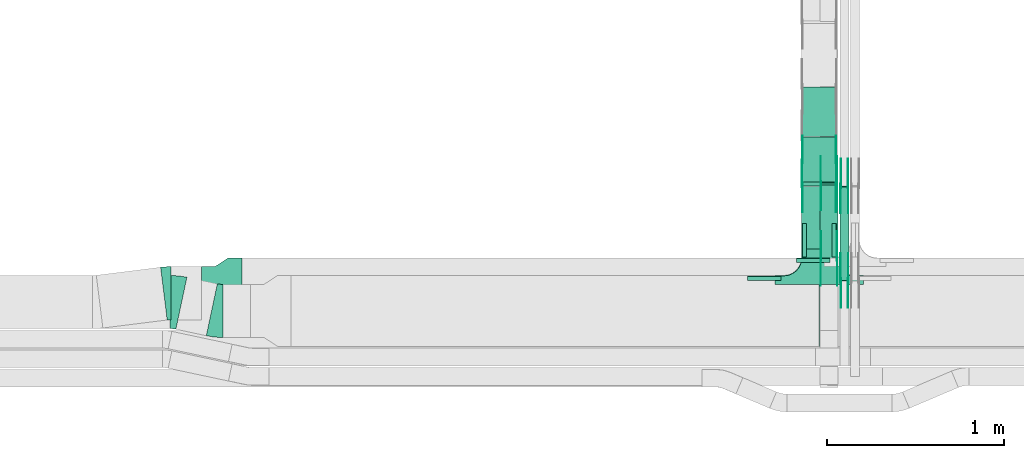
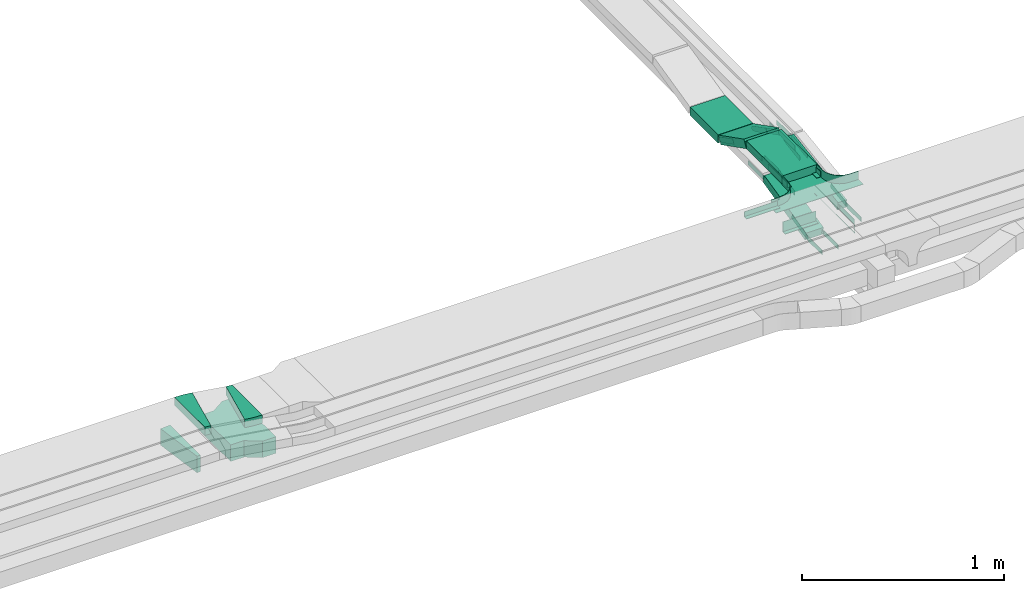
# One storey, part 17 of 27: 31 flow fittings, 5 flow segments.
"""IFC2X3 building model written with IfcOpenShell, lengths in millimetres."""

from ifc_helpers import new_model, entity, si_unit, converted_unit, derived_unit, direction, frame, frame_2d, origin, origin_2d_with_axis, place, context, subcontext, project, spatial, polyline, circle_curve, parameter, trimmed, segment, composite_curve, rectangle, outline, extrude, faceted_brep, source, transform, mapped, material, type_object, type_shapes, element, save


model = new_model("IFC2X3")

# Units and contexts
model_context = context("Model", 3, precision=0.01, world=origin(), true_north=direction((6.12303176911189e-17, 1.0)))
body_context = subcontext(model_context, "Body", "Model", "MODEL_VIEW")
ifc_project = project(units=[si_unit("LENGTHUNIT", "METRE", prefix="MILLI"), si_unit("AREAUNIT", "SQUARE_METRE"), si_unit("VOLUMEUNIT", "CUBIC_METRE"), converted_unit("PLANEANGLEUNIT", "DEGREE", entity("IfcRatioMeasure", 0.0174532925199433), si_unit("PLANEANGLEUNIT", "RADIAN"), dimensions=[0, 0, 0, 0, 0, 0, 0]), si_unit("MASSUNIT", "GRAM", prefix="KILO"), derived_unit("MASSDENSITYUNIT", [(si_unit("MASSUNIT", "GRAM", prefix="KILO"), 1), (si_unit("LENGTHUNIT", "METRE"), -3)]), derived_unit("MOMENTOFINERTIAUNIT", [(si_unit("LENGTHUNIT", "METRE"), 4)]), si_unit("TIMEUNIT", "SECOND"), si_unit("FREQUENCYUNIT", "HERTZ"), si_unit("THERMODYNAMICTEMPERATUREUNIT", "DEGREE_CELSIUS"), derived_unit("THERMALTRANSMITTANCEUNIT", [(si_unit("MASSUNIT", "GRAM", prefix="KILO"), 1), (si_unit("THERMODYNAMICTEMPERATUREUNIT", "KELVIN"), -1), (si_unit("TIMEUNIT", "SECOND"), -3)]), derived_unit("VOLUMETRICFLOWRATEUNIT", [(si_unit("LENGTHUNIT", "METRE"), 3), (si_unit("TIMEUNIT", "SECOND"), -1)]), derived_unit("MASSFLOWRATEUNIT", [(si_unit("MASSUNIT", "GRAM", prefix="KILO"), 1), (si_unit("TIMEUNIT", "SECOND"), -1)]), derived_unit("ROTATIONALFREQUENCYUNIT", [(si_unit("TIMEUNIT", "SECOND"), -1)]), si_unit("ELECTRICCURRENTUNIT", "AMPERE"), si_unit("ELECTRICVOLTAGEUNIT", "VOLT"), si_unit("POWERUNIT", "WATT"), si_unit("FORCEUNIT", "NEWTON", prefix="KILO"), si_unit("ILLUMINANCEUNIT", "LUX"), si_unit("LUMINOUSFLUXUNIT", "LUMEN"), si_unit("LUMINOUSINTENSITYUNIT", "CANDELA"), derived_unit("USERDEFINED", [(si_unit("MASSUNIT", "GRAM", prefix="KILO"), -1), (si_unit("LENGTHUNIT", "METRE"), -2), (si_unit("TIMEUNIT", "SECOND"), 3), (si_unit("LUMINOUSFLUXUNIT", "LUMEN"), 1)]), derived_unit("LINEARVELOCITYUNIT", [(si_unit("LENGTHUNIT", "METRE"), 1), (si_unit("TIMEUNIT", "SECOND"), -1)]), si_unit("PRESSUREUNIT", "PASCAL"), derived_unit("USERDEFINED", [(si_unit("LENGTHUNIT", "METRE"), -2), (si_unit("MASSUNIT", "GRAM", prefix="KILO"), 1), (si_unit("TIMEUNIT", "SECOND"), -2)]), derived_unit("LINEARFORCEUNIT", [(si_unit("MASSUNIT", "GRAM", prefix="KILO"), 1), (si_unit("LENGTHUNIT", "METRE"), 1), (si_unit("TIMEUNIT", "SECOND"), -2), (si_unit("LENGTHUNIT", "METRE"), -1)]), derived_unit("PLANARFORCEUNIT", [(si_unit("MASSUNIT", "GRAM", prefix="KILO"), 1), (si_unit("LENGTHUNIT", "METRE"), 1), (si_unit("TIMEUNIT", "SECOND"), -2), (si_unit("LENGTHUNIT", "METRE"), -2)])], contexts=[model_context])

# Site, building, storey
site_placement = place(None, origin())
site = spatial("IfcSite", under=ifc_project, at=site_placement, CompositionType="ELEMENT")
building_placement = place(site_placement, origin())
building = spatial("IfcBuilding", under=site, at=building_placement, CompositionType="ELEMENT")
storey_placement = place(building_placement, origin())
storey = spatial("IfcBuildingStorey", under=building, at=storey_placement, CompositionType="ELEMENT", Elevation=0.0)

# Flow segments
cable_carrier_segment_type = type_object("IfcCableCarrierSegmentType", PredefinedType="CABLETRAYSEGMENT")
flow_segment_1_placement = place(storey_placement, frame((46847.77, 9014.64, 2501.67)))
element("IfcFlowSegment", 1, at=flow_segment_1_placement, inside=storey, type_object=cable_carrier_segment_type, context=body_context, shape_type="SweptSolid", body=[
    extrude(rectangle(XDim=50.0000000000002, YDim=426.657179477889, at=frame_2d((0.0, 0.0), x_axis=(0.0, 1.0))), frame((0.0, 213.37, 73.33), z_axis=(1.0, 0.0, 0.0), x_axis=(0.0, -0.973268623518936, -0.229669733472992)), (0.0, 0.0, 1.0), 99.9999999999945),
])
flow_segment_2_placement = place(storey_placement, frame((46959.82, 8891.7, 2720.75)))
element("IfcFlowSegment", 2, at=flow_segment_2_placement, inside=storey, type_object=cable_carrier_segment_type, context=body_context, shape_type="SweptSolid", body=[
    extrude(rectangle(XDim=49.9999999999999, YDim=533.151523501312, at=frame_2d((0.0, 0.0), x_axis=(0.0, 1.0))), frame((0.0, 267.34, 64.25), z_axis=(1.0, 0.0, 0.0), x_axis=(0.0, 0.988943608506524, 0.148292073942251)), (0.0, 0.0, 1.0), 50.000000000006),
])
flow_segment_3_placement = place(storey_placement, frame((46742.18, 9070.0, 2850.0)))
element("IfcFlowSegment", 3, at=flow_segment_3_placement, inside=storey, type_object=cable_carrier_segment_type, context=body_context, shape_type="SweptSolid", body=[
    extrude(rectangle(XDim=352.037715986697, YDim=200.000000000007, at=origin_2d_with_axis()), frame((100.0, 176.02, 0.0), z_axis=(0.0, 0.0, 1.0), x_axis=(0.0, 1.0, 0.0)), (0.0, 0.0, 1.0), 49.9999999999995),
])
flow_segment_4_placement = place(storey_placement, frame((46742.18, 9425.74, 2720.14)))
element("IfcFlowSegment", 4, at=flow_segment_4_placement, inside=storey, type_object=cable_carrier_segment_type, context=body_context, shape_type="SweptSolid", body=[
    extrude(rectangle(XDim=49.9999999999994, YDim=284.075431974124, at=frame_2d((0.0, 0.0), x_axis=(0.0, 1.0))), frame((0.0, 137.91, 86.76), z_axis=(1.0, 0.0, 0.0), x_axis=(0.0, 0.891006524188341, -0.453990499739599)), (0.0, 0.0, 1.0), 200.000000000007),
])
flow_segment_5_placement = place(storey_placement, frame((46742.18, 9705.26, 2713.8)))
element("IfcFlowSegment", 5, at=flow_segment_5_placement, inside=storey, type_object=cable_carrier_segment_type, context=body_context, shape_type="SweptSolid", body=[
    extrude(rectangle(XDim=277.662391313806, YDim=200.000000000007, at=origin_2d_with_axis()), frame((100.0, 138.83, 0.0), z_axis=(0.0, 0.0, 1.0), x_axis=(0.0, 1.0, 0.0)), (0.0, 0.0, 1.0), 49.9999999999995),
])

# Flow fittings
ifc_material_1 = material()
cable_carrier_fitting_type_1 = type_object("IfcCableCarrierFittingType", PredefinedType="NOTDEFINED", material=ifc_material_1)
shared_shape_1 = source(origin(), body_context, "Body", "SweptSolid", [
    extrude(outline(polyline([(-21.5, -9.17), (40.5, -9.17), (40.5, -6.67), (-19.0, -6.67), (-19.0, 15.83), (-21.5, 15.83), (-21.5, -9.17)])), frame((-95.0, -9.17, -26.0), z_axis=(1.0, 0.0, 0.0), x_axis=(0.0, 0.0, 1.0)), (0.0, 0.0, 1.0), 190.0),
])
type_shapes(cable_carrier_fitting_type_1, [shared_shape_1])
flow_fitting_1_placement = place(storey_placement, frame((46809.82, 9017.67, 2650.0)))
element("IfcFlowFitting", 6, at=flow_fitting_1_placement, inside=storey, type_object=cable_carrier_fitting_type_1, material=ifc_material_1, context=body_context, shape_type="MappedRepresentation", body=[
    mapped(shared_shape_1, transform((0.0, 0.0, 0.0), scale=1.0)),
])
cable_carrier_fitting_type_2 = type_object("IfcCableCarrierFittingType", PredefinedType="NOTDEFINED", material=ifc_material_1)
shared_shape_2 = source(origin(), body_context, "Body", "SweptSolid", [
    extrude(outline(polyline([(-9.17, -11.5), (15.83, -11.5), (15.83, -9.0), (-6.67, -9.0), (-6.67, 20.5), (-9.17, 20.5), (-9.17, -11.5)])), frame((-95.0, 9.17, -11.0), z_axis=(1.0, 0.0, 0.0), x_axis=(0.0, 1.0, 0.0)), (0.0, 0.0, 1.0), 190.0),
])
type_shapes(cable_carrier_fitting_type_2, [shared_shape_2])
for number, where, z_axis, x_axis in (
    (7, (46744.68, 9120.0, 2875.0), (0.0, 0.0, 1.0), (0.0, -1.0, 0.0)),
    (8, (46939.68, 9120.0, 2875.0), (0.0, 0.0, 1.0), (0.0, 1.0, 0.0)),
):
    element("IfcFlowFitting", number, at=place(storey_placement, frame(where, z_axis=z_axis, x_axis=x_axis)), inside=storey, type_object=cable_carrier_fitting_type_2, material=ifc_material_1, context=body_context, shape_type="MappedRepresentation", body=[
        mapped(shared_shape_2, transform((0.0, 0.0, 0.0), scale=1.0)),
    ])
cable_carrier_fitting_type_3 = type_object("IfcCableCarrierFittingType", PredefinedType="NOTDEFINED", material=ifc_material_1)
shared_shape_3 = source(origin(), body_context, "Body", "SweptSolid", [
    extrude(outline(polyline([(-11.5, -9.17), (20.5, -9.17), (20.5, -6.67), (-9.0, -6.67), (-9.0, 15.83), (-11.5, 15.83), (-11.5, -9.17)])), frame((-95.0, -9.17, -11.0), z_axis=(1.0, 0.0, 0.0), x_axis=(0.0, 0.0, 1.0)), (0.0, 0.0, 1.0), 190.0),
])
type_shapes(cable_carrier_fitting_type_3, [shared_shape_3])
flow_fitting_2_placement = place(storey_placement, frame((46532.18, 8917.5, 2875.0)))
element("IfcFlowFitting", 9, at=flow_fitting_2_placement, inside=storey, type_object=cable_carrier_fitting_type_3, material=ifc_material_1, context=body_context, shape_type="MappedRepresentation", body=[
    mapped(shared_shape_3, transform((0.0, 0.0, 0.0), scale=1.0)),
])
ifc_material_2 = material()
cable_carrier_fitting_type_4 = type_object("IfcCableCarrierFittingType", PredefinedType="NOTDEFINED", material=ifc_material_2)
shared_shape_4 = source(origin(), body_context, "Body", "SweptSolid", [
    extrude(outline(polyline([(-115.0, -200.0), (-38.33, -200.0), (38.33, -150.0), (115.0, -150.0), (115.0, 150.0), (38.33, 150.0), (-38.33, 200.0), (-115.0, 200.0), (-115.0, -200.0)])), frame((115.0, 0.0, -50.0)), (0.0, 0.0, 1.0), 100.0),
])
type_shapes(cable_carrier_fitting_type_4, [shared_shape_4])
flow_fitting_3_placement = place(storey_placement, frame((43583.82, 8820.17, 2650.0), z_axis=(0.0, 0.0, 1.0), x_axis=(-1.0, 0.0, 0.0)))
element("IfcFlowFitting", 10, at=flow_fitting_3_placement, inside=storey, type_object=cable_carrier_fitting_type_4, material=ifc_material_2, Name="470_DKC_S5_adapter", context=body_context, shape_type="MappedRepresentation", body=[
    mapped(shared_shape_4, transform((0.0, 0.0, 0.0), scale=1.0)),
])
cable_carrier_fitting_type_5 = type_object("IfcCableCarrierFittingType", PredefinedType="NOTDEFINED", material=ifc_material_1)
shared_shape_5 = source(origin(), body_context, "Body", "Brep", [
    faceted_brep([(1.0, 197.5, 25.0), (1.0, 197.5, -22.5), (1.0, -200.0, -22.5), (1.0, -200.0, -25.0), (1.0, 200.0, -25.0), (1.0, 200.0, 25.0), (-1.0, 197.5, 25.0), (-1.0, 200.0, 25.0), (-1.0, 200.0, -25.0), (-1.0, -200.0, -25.0), (-1.0, -200.0, -22.5), (-1.0, 197.5, -22.5)], [[[0, 1, 2, 3, 4, 5]], [[6, 7, 8, 9, 10, 11]], [[1, 0, 6, 11]], [[2, 1, 11, 10]], [[3, 2, 10, 9]], [[4, 3, 9, 8]], [[5, 4, 8, 7]], [[0, 5, 7, 6]]]),
    faceted_brep([(97.5, -300.0, 25.0), (97.5, -350.0, 25.0), (100.0, -350.0, 25.0), (100.0, -300.0, 25.0), (103.41, -274.12, 25.0), (113.4, -250.0, 25.0), (129.29, -229.29, 25.0), (150.0, -213.4, 25.0), (174.12, -203.41, 25.0), (200.0, -200.0, 25.0), (250.0, -200.0, 25.0), (250.0, -197.5, 25.0), (200.0, -197.5, 25.0), (173.47, -200.99, 25.0), (148.75, -211.23, 25.0), (127.52, -227.52, 25.0), (111.23, -248.75, 25.0), (100.99, -273.47, 25.0), (-174.12, -203.41, 25.0), (-150.0, -213.4, 25.0), (-129.29, -229.29, 25.0), (-113.4, -250.0, 25.0), (-103.41, -274.12, 25.0), (-100.0, -300.0, 25.0), (-100.0, -350.0, 25.0), (-97.5, -350.0, 25.0), (-97.5, -300.0, 25.0), (-100.99, -273.47, 25.0), (-111.23, -248.75, 25.0), (-127.52, -227.52, 25.0), (-148.75, -211.23, 25.0), (-173.47, -200.99, 25.0), (-200.0, -197.5, 25.0), (-250.0, -197.5, 25.0), (-250.0, -200.0, 25.0), (-200.0, -200.0, 25.0), (-200.0, -200.0, -25.0), (-189.21, -201.42, -25.0), (-174.12, -203.41, -25.0), (-200.0, -200.0, -27.5), (-187.06, -201.7, -27.5), (-174.12, -203.41, -27.5), (-162.06, -208.4, -25.0), (-150.0, -213.4, -25.0), (-162.06, -208.4, -27.5), (-150.0, -213.4, -27.5), (-139.64, -221.34, -25.0), (-129.29, -229.29, -25.0), (-139.64, -221.34, -27.5), (-129.29, -229.29, -27.5), (-113.4, -250.0, -25.0), (-108.4, -262.06, -25.0), (-103.41, -274.12, -25.0), (-113.4, -250.0, -27.5), (-108.4, -262.06, -27.5), (-103.41, -274.12, -27.5), (-101.7, -287.06, -25.0), (-100.0, -300.0, -25.0), (-101.42, -289.21, -27.5), (-100.0, -300.0, -27.5), (-121.34, -239.64, -25.0), (-121.34, -239.64, -27.5), (-100.0, -350.0, -27.5), (100.0, -350.0, -27.5), (97.5, -350.0, -25.0), (-97.5, -350.0, -25.0), (-97.5, -300.0, -25.0), (-100.99, -273.47, -25.0), (-111.23, -248.75, -25.0), (-127.52, -227.52, -25.0), (-148.75, -211.23, -25.0), (-173.47, -200.99, -25.0), (-200.0, -197.5, -25.0), (100.0, -300.0, -27.5), (100.0, -300.0, -25.0), (103.41, -274.12, -25.0), (101.42, -289.21, -25.0), (101.7, -287.06, -27.5), (103.41, -274.12, -27.5), (113.4, -250.0, -25.0), (108.4, -262.06, -25.0), (108.4, -262.06, -27.5), (113.4, -250.0, -27.5), (121.34, -239.64, -25.0), (129.29, -229.29, -25.0), (121.34, -239.64, -27.5), (129.29, -229.29, -27.5), (150.0, -213.4, -25.0), (139.64, -221.34, -25.0), (139.64, -221.34, -27.5), (150.0, -213.4, -27.5), (174.12, -203.41, -25.0), (162.06, -208.4, -25.0), (162.06, -208.4, -27.5), (174.12, -203.41, -27.5), (187.06, -201.7, -25.0), (200.0, -200.0, -25.0), (189.21, -201.42, -27.5), (200.0, -200.0, -27.5), (200.0, -197.5, -25.0), (173.47, -200.99, -25.0), (148.75, -211.23, -25.0), (127.52, -227.52, -25.0), (111.23, -248.75, -25.0), (100.99, -273.47, -25.0), (97.5, -300.0, -25.0), (-250.0, -197.5, -25.0), (250.0, -197.5, -25.0), (-250.0, -150.0, -25.0), (-250.0, -150.0, -27.5), (-250.0, -200.0, -27.5), (250.0, -200.0, -27.5), (250.0, -150.0, -27.5), (250.0, -150.0, -25.0)], [[[0, 1, 2, 3, 4, 5, 6, 7, 8, 9, 10, 11, 12, 13, 14, 15, 16, 17]], [[18, 19, 20, 21, 22, 23, 24, 25, 26, 27, 28, 29, 30, 31, 32, 33, 34, 35]], [[18, 35, 36]], [[18, 36, 37]], [[18, 37, 38]], [[37, 36, 39]], [[37, 39, 40]], [[38, 40, 41]], [[37, 40, 38]], [[19, 18, 38]], [[19, 38, 42]], [[19, 42, 43]], [[38, 41, 42]], [[44, 42, 41]], [[42, 44, 43]], [[44, 45, 43]], [[20, 43, 46]], [[19, 43, 20]], [[20, 46, 47]], [[46, 43, 45]], [[46, 45, 48]], [[48, 49, 47]], [[46, 48, 47]], [[22, 21, 50]], [[22, 50, 51]], [[22, 51, 52]], [[50, 53, 51]], [[54, 51, 53]], [[51, 54, 52]], [[54, 55, 52]], [[23, 22, 52]], [[23, 52, 56]], [[23, 56, 57]], [[52, 55, 56]], [[58, 56, 55]], [[58, 59, 57]], [[56, 58, 57]], [[21, 47, 60]], [[20, 47, 21]], [[21, 60, 50]], [[60, 47, 49]], [[60, 49, 61]], [[60, 61, 50]], [[61, 53, 50]], [[24, 23, 57, 59, 62]], [[25, 24, 62, 63, 2, 1, 64, 65]], [[26, 25, 65, 66]], [[27, 26, 66, 67]], [[28, 27, 67, 68]], [[29, 28, 68, 69]], [[30, 29, 69, 70]], [[31, 30, 70, 71]], [[32, 31, 71, 72]], [[3, 2, 63, 73, 74]], [[4, 3, 75]], [[3, 76, 75]], [[3, 74, 76]], [[76, 74, 73]], [[76, 73, 77]], [[75, 77, 78]], [[76, 77, 75]], [[5, 4, 79]], [[4, 80, 79]], [[4, 75, 80]], [[75, 78, 80]], [[81, 80, 78]], [[80, 81, 79]], [[81, 82, 79]], [[5, 79, 83]], [[5, 83, 84]], [[84, 6, 5]], [[83, 79, 82]], [[83, 82, 85]], [[85, 86, 84]], [[83, 85, 84]], [[7, 6, 87]], [[6, 88, 87]], [[6, 84, 88]], [[88, 84, 86]], [[88, 86, 89]], [[88, 89, 87]], [[89, 90, 87]], [[8, 7, 91]], [[7, 92, 91]], [[7, 87, 92]], [[87, 90, 92]], [[93, 92, 90]], [[92, 93, 91]], [[93, 94, 91]], [[8, 91, 95]], [[8, 95, 96]], [[8, 96, 9]], [[91, 94, 95]], [[97, 95, 94]], [[97, 98, 96]], [[95, 97, 96]], [[13, 12, 99, 100]], [[14, 13, 100, 101]], [[15, 14, 101, 102]], [[102, 103, 16, 15]], [[17, 16, 103, 104]], [[104, 105, 0, 17]], [[1, 0, 105, 64]], [[33, 32, 72, 106]], [[12, 11, 107, 99]], [[34, 33, 106, 108, 109, 110]], [[35, 34, 110, 39, 36]], [[10, 9, 96, 98, 111]], [[10, 111, 112, 113, 107, 11]], [[107, 113, 108, 106, 72, 71, 70, 69, 68, 67, 66, 65, 64, 105, 104, 103, 102, 101, 100, 99]], [[110, 109, 112, 111, 98, 97, 94, 93, 90, 89, 86, 85, 82, 81, 78, 77, 73, 63, 62, 59, 58, 55, 54, 53, 61, 49, 48, 45, 44, 41, 40, 39]], [[108, 113, 112, 109]]]),
])
type_shapes(cable_carrier_fitting_type_5, [shared_shape_5])
flow_fitting_4_placement = place(storey_placement, frame((46842.18, 8720.0, 2875.0), z_axis=(0.0, 0.0, 1.0), x_axis=(-1.0, 0.0, 0.0)))
element("IfcFlowFitting", 11, at=flow_fitting_4_placement, inside=storey, type_object=cable_carrier_fitting_type_5, material=ifc_material_1, context=body_context, shape_type="MappedRepresentation", body=[
    mapped(shared_shape_5, transform((0.0, 0.0, 0.0), scale=1.0)),
])
ifc_material_3 = material(Name="G")
cable_carrier_fitting_type_6 = type_object("IfcCableCarrierFittingType", PredefinedType="NOTDEFINED", material=ifc_material_3)
shared_shape_6 = source(origin(), body_context, "Body", "SweptSolid", [
    extrude(outline(composite_curve([segment(trimmed(circle_curve(frame_2d((-44.59, 0.0), x_axis=(1.0, 0.0)), 12.5), [parameter(90.0000000000007)], [parameter(270.0)], True, "PARAMETER"), True, "CONTINUOUS"), segment(polyline([(-44.59, -12.5), (-33.09, -12.5)]), True, "CONTINUOUS"), segment(polyline([(-33.09, -12.5), (-31.23, -14.5)]), True, "CONTINUOUS"), segment(polyline([(-31.23, -14.5), (108.91, -14.5)]), True, "CONTINUOUS"), segment(polyline([(108.91, -14.5), (108.91, 14.5)]), True, "CONTINUOUS"), segment(polyline([(108.91, 14.5), (-31.23, 14.5)]), True, "CONTINUOUS"), segment(polyline([(-31.23, 14.5), (-33.09, 12.5)]), True, "CONTINUOUS"), segment(polyline([(-33.09, 12.5), (-44.59, 12.5)]), True, "CONTINUOUS")], self_intersect=False)), frame((44.59, 0.0, 0.0), z_axis=(0.0, 0.0, -1.0), x_axis=(1.0, 0.0, 0.0)), (0.0, 0.0, -1.0), 2.0),
])
type_shapes(cable_carrier_fitting_type_6, [shared_shape_6])
flow_fitting_5_placement = place(storey_placement, frame((46852.31, 9439.9, 2625.0), z_axis=(-1.0, 0.0, 0.0), x_axis=(0.0, 1.0, 0.0)))
element("IfcFlowFitting", 12, at=flow_fitting_5_placement, inside=storey, type_object=cable_carrier_fitting_type_6, material=ifc_material_3, context=body_context, shape_type="MappedRepresentation", body=[
    mapped(shared_shape_6, transform((0.0, 0.0, 0.0), scale=1.0)),
])
cable_carrier_fitting_type_7 = type_object("IfcCableCarrierFittingType", PredefinedType="NOTDEFINED", material=ifc_material_3)
type_shapes(cable_carrier_fitting_type_7, [shared_shape_6])
flow_fitting_6_placement = place(storey_placement, frame((46941.23, 9439.9, 2625.0), z_axis=(1.0, 0.0, 0.0), x_axis=(0.0, -0.973268623517807, -0.229669733477778)))
element("IfcFlowFitting", 13, at=flow_fitting_6_placement, inside=storey, type_object=cable_carrier_fitting_type_7, material=ifc_material_3, context=body_context, shape_type="MappedRepresentation", body=[
    mapped(shared_shape_6, transform((0.0, 0.0, 0.0), scale=1.0)),
])
flow_fitting_7_placement = place(storey_placement, frame((46852.31, 9016.13, 2525.0), z_axis=(-1.0, 0.0, 0.0), x_axis=(0.0, -1.0, 0.0)))
element("IfcFlowFitting", 14, at=flow_fitting_7_placement, inside=storey, type_object=cable_carrier_fitting_type_6, material=ifc_material_3, context=body_context, shape_type="MappedRepresentation", body=[
    mapped(shared_shape_6, transform((0.0, 0.0, 0.0), scale=1.0)),
])
flow_fitting_8_placement = place(storey_placement, frame((46941.23, 9016.13, 2525.0), z_axis=(1.0, 0.0, 0.0), x_axis=(0.0, 0.973268623517807, 0.229669733477778)))
element("IfcFlowFitting", 15, at=flow_fitting_8_placement, inside=storey, type_object=cable_carrier_fitting_type_7, material=ifc_material_3, context=body_context, shape_type="MappedRepresentation", body=[
    mapped(shared_shape_6, transform((0.0, 0.0, 0.0), scale=1.0)),
])
flow_fitting_9_placement = place(storey_placement, frame((47005.28, 8892.28, 2745.0), z_axis=(1.0, 0.0, 0.0), x_axis=(0.0, 0.988943608506527, 0.148292073942234)))
element("IfcFlowFitting", 16, at=flow_fitting_9_placement, inside=storey, type_object=cable_carrier_fitting_type_6, material=ifc_material_3, context=body_context, shape_type="MappedRepresentation", body=[
    mapped(shared_shape_6, transform((0.0, 0.0, 0.0), scale=1.0)),
])
flow_fitting_10_placement = place(storey_placement, frame((46966.36, 8892.28, 2745.0), z_axis=(-1.0, 0.0, 0.0), x_axis=(0.0, -1.0, 0.0)))
element("IfcFlowFitting", 17, at=flow_fitting_10_placement, inside=storey, type_object=cable_carrier_fitting_type_7, material=ifc_material_3, context=body_context, shape_type="MappedRepresentation", body=[
    mapped(shared_shape_6, transform((0.0, 0.0, 0.0), scale=1.0)),
])
flow_fitting_11_placement = place(storey_placement, frame((47005.28, 9425.79, 2825.0), z_axis=(1.0, 0.0, 0.0), x_axis=(0.0, -0.988943608506527, -0.148292073942234)))
element("IfcFlowFitting", 18, at=flow_fitting_11_placement, inside=storey, type_object=cable_carrier_fitting_type_6, material=ifc_material_3, context=body_context, shape_type="MappedRepresentation", body=[
    mapped(shared_shape_6, transform((0.0, 0.0, 0.0), scale=1.0)),
])
flow_fitting_12_placement = place(storey_placement, frame((46966.36, 9425.79, 2825.0), z_axis=(-1.0, 0.0, 0.0), x_axis=(0.0, 1.0, 0.0)))
element("IfcFlowFitting", 19, at=flow_fitting_12_placement, inside=storey, type_object=cable_carrier_fitting_type_7, material=ifc_material_3, context=body_context, shape_type="MappedRepresentation", body=[
    mapped(shared_shape_6, transform((0.0, 0.0, 0.0), scale=1.0)),
])
flow_fitting_13_placement = place(storey_placement, frame((46746.72, 9430.0, 2875.0), z_axis=(-1.0, 0.0, 0.0), x_axis=(0.0, 0.891006524188341, -0.4539904997396)))
element("IfcFlowFitting", 20, at=flow_fitting_13_placement, inside=storey, type_object=cable_carrier_fitting_type_6, material=ifc_material_3, context=body_context, shape_type="MappedRepresentation", body=[
    mapped(shared_shape_6, transform((0.0, 0.0, 0.0), scale=1.0)),
])
for number, where, z_axis, x_axis in (
    (21, (46935.64, 9430.0, 2875.0), (1.0, 0.0, 0.0), (0.0, -1.0, 0.0)),
    (22, (46748.72, 9697.3, 2738.8), (-1.0, 0.0, 0.0), (0.0, -0.891006524188359, 0.453990499739564)),
):
    element("IfcFlowFitting", number, at=place(storey_placement, frame(where, z_axis=z_axis, x_axis=x_axis)), inside=storey, type_object=cable_carrier_fitting_type_7, material=ifc_material_3, context=body_context, shape_type="MappedRepresentation", body=[
        mapped(shared_shape_6, transform((0.0, 0.0, 0.0), scale=1.0)),
    ])
cable_carrier_fitting_type_8 = type_object("IfcCableCarrierFittingType", PredefinedType="NOTDEFINED", material=ifc_material_3)
shared_shape_7 = source(origin(), body_context, "Body", "SweptSolid", [
    extrude(outline(composite_curve([segment(trimmed(circle_curve(frame_2d((-44.59, 0.0), x_axis=(1.0, 0.0)), 12.5), [parameter(90.0000000000007)], [parameter(270.0)], True, "PARAMETER"), True, "CONTINUOUS"), segment(polyline([(-44.59, -12.5), (-33.09, -12.5)]), True, "CONTINUOUS"), segment(polyline([(-33.09, -12.5), (-31.23, -14.5)]), True, "CONTINUOUS"), segment(polyline([(-31.23, -14.5), (108.91, -14.5)]), True, "CONTINUOUS"), segment(polyline([(108.91, -14.5), (108.91, 14.5)]), True, "CONTINUOUS"), segment(polyline([(108.91, 14.5), (-31.23, 14.5)]), True, "CONTINUOUS"), segment(polyline([(-31.23, 14.5), (-33.09, 12.5)]), True, "CONTINUOUS"), segment(polyline([(-33.09, 12.5), (-44.59, 12.5)]), True, "CONTINUOUS")], self_intersect=False)), frame((44.59, 0.0, 0.0)), (0.0, 0.0, 1.0), 2.0),
])
type_shapes(cable_carrier_fitting_type_8, [shared_shape_7])
flow_fitting_14_placement = place(storey_placement, frame((46943.23, 9439.9, 2625.0), z_axis=(1.0, 0.0, 0.0), x_axis=(0.0, 1.0, 0.0)))
element("IfcFlowFitting", 23, at=flow_fitting_14_placement, inside=storey, type_object=cable_carrier_fitting_type_8, material=ifc_material_3, context=body_context, shape_type="MappedRepresentation", body=[
    mapped(shared_shape_7, transform((0.0, 0.0, 0.0), scale=1.0)),
])
cable_carrier_fitting_type_9 = type_object("IfcCableCarrierFittingType", PredefinedType="NOTDEFINED", material=ifc_material_3)
type_shapes(cable_carrier_fitting_type_9, [shared_shape_7])
flow_fitting_15_placement = place(storey_placement, frame((46854.31, 9439.9, 2625.0), z_axis=(-1.0, 0.0, 0.0), x_axis=(0.0, -0.973268623517807, -0.229669733477778)))
element("IfcFlowFitting", 24, at=flow_fitting_15_placement, inside=storey, type_object=cable_carrier_fitting_type_9, material=ifc_material_3, context=body_context, shape_type="MappedRepresentation", body=[
    mapped(shared_shape_7, transform((0.0, 0.0, 0.0), scale=1.0)),
])
flow_fitting_16_placement = place(storey_placement, frame((46943.23, 9016.13, 2525.0), z_axis=(1.0, 0.0, 0.0), x_axis=(0.0, -1.0, 0.0)))
element("IfcFlowFitting", 25, at=flow_fitting_16_placement, inside=storey, type_object=cable_carrier_fitting_type_8, material=ifc_material_3, context=body_context, shape_type="MappedRepresentation", body=[
    mapped(shared_shape_7, transform((0.0, 0.0, 0.0), scale=1.0)),
])
flow_fitting_17_placement = place(storey_placement, frame((46854.31, 9016.13, 2525.0), z_axis=(-1.0, 0.0, 0.0), x_axis=(0.0, 0.973268623517807, 0.229669733477778)))
element("IfcFlowFitting", 26, at=flow_fitting_17_placement, inside=storey, type_object=cable_carrier_fitting_type_9, material=ifc_material_3, context=body_context, shape_type="MappedRepresentation", body=[
    mapped(shared_shape_7, transform((0.0, 0.0, 0.0), scale=1.0)),
])
flow_fitting_18_placement = place(storey_placement, frame((46964.36, 8892.28, 2745.0), z_axis=(-1.0, 0.0, 0.0), x_axis=(0.0, 0.988943608506527, 0.148292073942234)))
element("IfcFlowFitting", 27, at=flow_fitting_18_placement, inside=storey, type_object=cable_carrier_fitting_type_8, material=ifc_material_3, context=body_context, shape_type="MappedRepresentation", body=[
    mapped(shared_shape_7, transform((0.0, 0.0, 0.0), scale=1.0)),
])
flow_fitting_19_placement = place(storey_placement, frame((47003.28, 8892.28, 2745.0), z_axis=(1.0, 0.0, 0.0), x_axis=(0.0, -1.0, 0.0)))
element("IfcFlowFitting", 28, at=flow_fitting_19_placement, inside=storey, type_object=cable_carrier_fitting_type_9, material=ifc_material_3, context=body_context, shape_type="MappedRepresentation", body=[
    mapped(shared_shape_7, transform((0.0, 0.0, 0.0), scale=1.0)),
])
flow_fitting_20_placement = place(storey_placement, frame((46964.36, 9425.79, 2825.0), z_axis=(-1.0, 0.0, 0.0), x_axis=(0.0, -0.988943608506527, -0.148292073942234)))
element("IfcFlowFitting", 29, at=flow_fitting_20_placement, inside=storey, type_object=cable_carrier_fitting_type_8, material=ifc_material_3, context=body_context, shape_type="MappedRepresentation", body=[
    mapped(shared_shape_7, transform((0.0, 0.0, 0.0), scale=1.0)),
])
flow_fitting_21_placement = place(storey_placement, frame((47003.28, 9425.79, 2825.0), z_axis=(1.0, 0.0, 0.0), x_axis=(0.0, 1.0, 0.0)))
element("IfcFlowFitting", 30, at=flow_fitting_21_placement, inside=storey, type_object=cable_carrier_fitting_type_9, material=ifc_material_3, context=body_context, shape_type="MappedRepresentation", body=[
    mapped(shared_shape_7, transform((0.0, 0.0, 0.0), scale=1.0)),
])
flow_fitting_22_placement = place(storey_placement, frame((46937.64, 9430.0, 2875.0), z_axis=(1.0, 0.0, 0.0), x_axis=(0.0, 0.891006524188341, -0.4539904997396)))
element("IfcFlowFitting", 31, at=flow_fitting_22_placement, inside=storey, type_object=cable_carrier_fitting_type_8, material=ifc_material_3, context=body_context, shape_type="MappedRepresentation", body=[
    mapped(shared_shape_7, transform((0.0, 0.0, 0.0), scale=1.0)),
])
for number, where, z_axis, x_axis in (
    (32, (46748.72, 9430.0, 2875.0), (-1.0, 0.0, 0.0), (0.0, -1.0, 0.0)),
    (33, (46935.64, 9697.3, 2738.8), (1.0, 0.0, 0.0), (0.0, -0.891006524188359, 0.453990499739564)),
):
    element("IfcFlowFitting", number, at=place(storey_placement, frame(where, z_axis=z_axis, x_axis=x_axis)), inside=storey, type_object=cable_carrier_fitting_type_9, material=ifc_material_3, context=body_context, shape_type="MappedRepresentation", body=[
        mapped(shared_shape_7, transform((0.0, 0.0, 0.0), scale=1.0)),
    ])
cable_carrier_fitting_type_10 = type_object("IfcCableCarrierFittingType", Name="470_DKC_S5_Variable Angle Elbow 0-45:-", PredefinedType="NOTDEFINED", material=ifc_material_2)
shared_shape_8 = source(origin(), body_context, "Body", "SweptSolid", [
    extrude(outline(composite_curve([segment(polyline([(-32.18, -153.33), (-31.18, -153.33)]), True, "CONTINUOUS"), segment(trimmed(circle_curve(frame_2d((-31.18, 296.67), x_axis=(0.0, -1.0)), 450.0), [parameter(0.0)], [parameter(12.0000000000001)], True, "PARAMETER"), True, "CONTINUOUS"), segment(polyline([(62.38, -143.5), (63.36, -143.29)]), True, "CONTINUOUS"), segment(polyline([(63.36, -143.29), (0.98, 150.16)]), True, "CONTINUOUS"), segment(polyline([(0.98, 150.16), (0.01, 149.95)]), True, "CONTINUOUS"), segment(trimmed(circle_curve(frame_2d((-31.18, 296.67), x_axis=(0.0, -1.0)), 150.0), [parameter(0.0)], [parameter(12.0000000000001)], True, "PARAMETER"), False, "CONTINUOUS"), segment(polyline([(-31.18, 146.67), (-32.18, 146.67)]), True, "CONTINUOUS"), segment(polyline([(-32.18, 146.67), (-32.18, -153.33)]), True, "CONTINUOUS")], self_intersect=False)), frame((-0.35, 3.33, -25.0)), (0.0, 0.0, 1.0), 49.9999999999997),
])
type_shapes(cable_carrier_fitting_type_10, [shared_shape_8])
for number, where, z_axis, x_axis, name in (
    (34, (43444.81, 8720.0, 2875.0), (0.0, 0.0, 1.0), (0.978147600733805, -0.207911690817761, 0.0), "470_DKC_S5_Variable Angle Elbow 0-45:-"),
    (35, (43209.58, 8770.0, 2875.0), (0.0, 0.0, 1.0), (-0.978147600733808, 0.207911690817749, 0.0), "470_DKC_S5_Variable Angle Elbow 0-45:-"),
):
    element("IfcFlowFitting", number, at=place(storey_placement, frame(where, z_axis=z_axis, x_axis=x_axis)), inside=storey, type_object=cable_carrier_fitting_type_10, material=ifc_material_2, Name=name, ObjectType="470_DKC_S5_Variable Angle Elbow 0-45:-", context=body_context, shape_type="MappedRepresentation", body=[
        mapped(shared_shape_8, transform((0.0, 0.0, 0.0), scale=1.0)),
    ])
cable_carrier_fitting_type_11 = type_object("IfcCableCarrierFittingType", Name="470_DKC_S5_Variable Angle Elbow 0-45:-", PredefinedType="NOTDEFINED", material=ifc_material_2)
shared_shape_9 = source(origin(), body_context, "Body", "SweptSolid", [
    extrude(outline(composite_curve([segment(polyline([(-19.58, -151.19), (-18.58, -151.19)]), True, "CONTINUOUS"), segment(trimmed(circle_curve(frame_2d((-18.58, 298.81), x_axis=(0.0, -1.0)), 450.0), [parameter(0.0)], [parameter(7.11451349008865)], True, "PARAMETER"), True, "CONTINUOUS"), segment(polyline([(37.16, -147.72), (38.15, -147.6)]), True, "CONTINUOUS"), segment(polyline([(38.15, -147.6), (0.99, 150.09)]), True, "CONTINUOUS"), segment(polyline([(0.99, 150.09), (0.0, 149.97)]), True, "CONTINUOUS"), segment(trimmed(circle_curve(frame_2d((-18.58, 298.81), x_axis=(0.0, -1.0)), 150.0), [parameter(0.0)], [parameter(7.11451349008865)], True, "PARAMETER"), False, "CONTINUOUS"), segment(polyline([(-18.58, 148.81), (-19.58, 148.81)]), True, "CONTINUOUS"), segment(polyline([(-19.58, 148.81), (-19.58, -151.19)]), True, "CONTINUOUS")], self_intersect=False)), frame((-0.07, 1.19, -50.0)), (0.0, 0.0, 1.0), 99.9999999999998),
])
type_shapes(cable_carrier_fitting_type_11, [shared_shape_9])
flow_fitting_23_placement = place(storey_placement, frame((43161.82, 8820.17, 2650.0), z_axis=(0.0, 0.0, 1.0), x_axis=(-1.0, 0.0, 0.0)))
element("IfcFlowFitting", 36, at=flow_fitting_23_placement, inside=storey, type_object=cable_carrier_fitting_type_11, material=ifc_material_2, Name="470_DKC_S5_Variable Angle Elbow 0-45:-", ObjectType="470_DKC_S5_Variable Angle Elbow 0-45:-", context=body_context, shape_type="MappedRepresentation", body=[
    mapped(shared_shape_9, transform((0.0, 0.0, 0.0), scale=1.0)),
])

save(model, "model.ifc")
